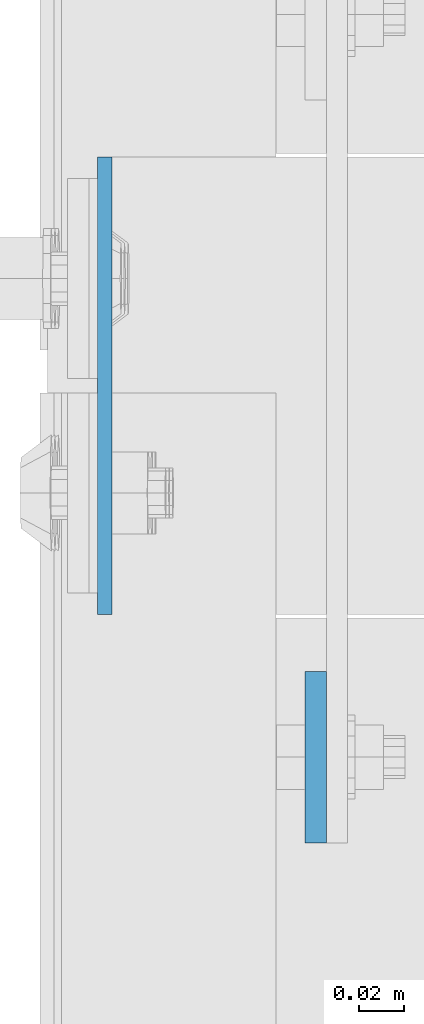
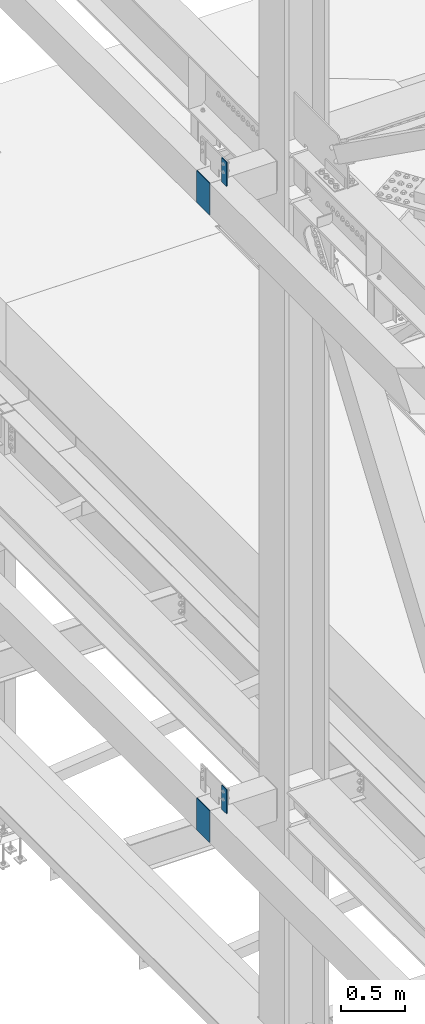
# One storey, part 1552 of 3843: 4 columns, 3 elements without a shape of their own.
"""IFC2X3 building model written with IfcOpenShell, lengths in millimetres."""

from ifc_helpers import new_model, si_unit, frame, origin_with_axes, place, context, subcontext, project, spatial, faceted_brep, material, type_object, element, aggregate, save


model = new_model("IFC2X3")

# Units and contexts
model_context = context("Model", 3, precision=1e-05, world=origin_with_axes())
body_context = subcontext(model_context, "Body", "Model", "MODEL_VIEW")
ifc_project = project(units=[si_unit("LENGTHUNIT", "METRE", prefix="MILLI"), si_unit("AREAUNIT", "SQUARE_METRE"), si_unit("VOLUMEUNIT", "CUBIC_METRE"), si_unit("MASSUNIT", "GRAM", prefix="KILO"), si_unit("TIMEUNIT", "SECOND"), si_unit("PLANEANGLEUNIT", "RADIAN"), si_unit("SOLIDANGLEUNIT", "STERADIAN"), si_unit("THERMODYNAMICTEMPERATUREUNIT", "DEGREE_CELSIUS"), si_unit("LUMINOUSINTENSITYUNIT", "LUMEN")], contexts=[model_context])

# Site, building, storey
site_placement = place(None, origin_with_axes())
site = spatial("IfcSite", under=ifc_project, at=site_placement, CompositionType="ELEMENT")
building_placement = place(site_placement, origin_with_axes())
building = spatial("IfcBuilding", under=site, at=building_placement, Name="Undefined", CompositionType="ELEMENT")
storey_placement = place(building_placement, origin_with_axes())
storey = spatial("IfcBuildingStorey", under=building, at=storey_placement, Name="Undefined", CompositionType="ELEMENT", Elevation=0.0)

# Assembly, columns
assembly_1_placement = place(storey_placement, origin_with_axes())
assembly_1 = element("IfcElementAssembly", 1, at=assembly_1_placement, inside=storey, Name="COLUMN", AssemblyPlace="NOTDEFINED", PredefinedType="RIGID_FRAME")
ifc_material = material(Name="STEEL/A572-50")
column_type_1 = type_object("IfcColumnType", PredefinedType="NOTDEFINED")
column_1_placement = place(assembly_1_placement, frame((35763.2, 75628.5, 42062.4), z_axis=(0.0, -1.0, 0.0), x_axis=(0.0, 0.0, 1.0)))
column_1 = element("IfcColumn", 2, at=column_1_placement, type_object=column_type_1, material=ifc_material, Name="PLATE", context=body_context, shape_type="Brep", body=[
    faceted_brep([(0.0, 3.17499999999927, -101.600000000006), (0.0, 3.17499999999927, 101.600000000006), (304.800000000003, 3.17499999999927, 101.600000000006), (304.800000000003, 3.17499999999927, -101.600000000006), (0.0, -3.17499999999927, 101.600000000006), (304.800000000003, -3.17499999999927, 101.600000000006), (0.0, -3.17499999999927, -101.600000000006), (304.800000000003, -3.17499999999927, -101.600000000006)], [[[0, 1, 2, 3]], [[1, 4, 5, 2]], [[4, 6, 7, 5]], [[6, 0, 3, 7]], [[5, 7, 3, 2]], [[6, 4, 1, 0]]]),
])
column_2_placement = place(assembly_1_placement, frame((35763.2, 75628.5, 36099.75), z_axis=(0.0, -1.0, 0.0), x_axis=(0.0, 0.0, 1.0)))
column_2 = element("IfcColumn", 3, at=column_2_placement, type_object=column_type_1, material=ifc_material, Name="PLATE", context=body_context, shape_type="Brep", body=[
    faceted_brep([(0.0, 3.17499999999927, -101.600000000006), (0.0, 3.17499999999927, 101.600000000006), (304.800000000003, 3.17499999999927, 101.600000000006), (304.800000000003, 3.17499999999927, -101.600000000006), (0.0, -3.17499999999927, 101.600000000006), (304.800000000003, -3.17499999999927, 101.600000000006), (0.0, -3.17499999999927, -101.600000000006), (304.800000000003, -3.17499999999927, -101.600000000006)], [[[0, 1, 2, 3]], [[1, 4, 5, 2]], [[4, 6, 7, 5]], [[6, 0, 3, 7]], [[5, 7, 3, 2]], [[6, 4, 1, 0]]]),
])
aggregate(assembly_1, [column_1, column_2])

# Assembly, column
assembly_2_placement = place(storey_placement, origin_with_axes())
assembly_2 = element("IfcElementAssembly", 4, at=assembly_2_placement, inside=storey, Name="GIRT", AssemblyPlace="NOTDEFINED", PredefinedType="RIGID_FRAME")
column_type_2 = type_object("IfcColumnType", PredefinedType="NOTDEFINED")
column_3_placement = place(assembly_2_placement, frame((35856.8625, 75463.4, 36404.55), z_axis=(0.0, 1.0, 0.0), x_axis=(0.0, 0.0, 1.0)))
column_3 = element("IfcColumn", 5, at=column_3_placement, type_object=column_type_2, material=ifc_material, Name="PLATE", context=body_context, shape_type="Brep", body=[
    faceted_brep([(0.0, 4.76250000000073, -38.0999999999985), (0.0, 4.76250000000073, 38.0999999999985), (228.599999999999, 4.76249999999709, 38.1000000000058), (228.599999999999, 4.76249999999709, -38.1000000000058), (0.0, -4.76250000000073, 38.0999999999985), (228.599999999999, -4.76249999999709, 38.1000000000058), (0.0, -4.76250000000073, -38.0999999999985), (228.599999999999, -4.76249999999709, -38.1000000000058)], [[[0, 1, 2, 3]], [[1, 4, 5, 2]], [[4, 6, 7, 5]], [[6, 0, 3, 7]], [[5, 7, 3, 2]], [[6, 4, 1, 0]]]),
])
aggregate(assembly_2, [column_3])

assembly_3_placement = place(storey_placement, origin_with_axes())
assembly_3 = element("IfcElementAssembly", 6, at=assembly_3_placement, inside=storey, Name="GIRT", AssemblyPlace="NOTDEFINED", PredefinedType="RIGID_FRAME")
column_4_placement = place(assembly_3_placement, frame((35856.8625, 75463.4, 42367.2), z_axis=(0.0, 1.0, 0.0), x_axis=(0.0, 0.0, 1.0)))
column_4 = element("IfcColumn", 7, at=column_4_placement, type_object=column_type_2, material=ifc_material, Name="PLATE", context=body_context, shape_type="Brep", body=[
    faceted_brep([(0.0, 4.76250000000073, -38.0999999999985), (0.0, 4.76250000000073, 38.0999999999985), (228.599999999999, 4.76249999999709, 38.1000000000058), (228.599999999999, 4.76249999999709, -38.1000000000058), (0.0, -4.76250000000073, 38.0999999999985), (228.599999999999, -4.76249999999709, 38.1000000000058), (0.0, -4.76250000000073, -38.0999999999985), (228.599999999999, -4.76249999999709, -38.1000000000058)], [[[0, 1, 2, 3]], [[1, 4, 5, 2]], [[4, 6, 7, 5]], [[6, 0, 3, 7]], [[5, 7, 3, 2]], [[6, 4, 1, 0]]]),
])
aggregate(assembly_3, [column_4])

save(model, "model.ifc")
